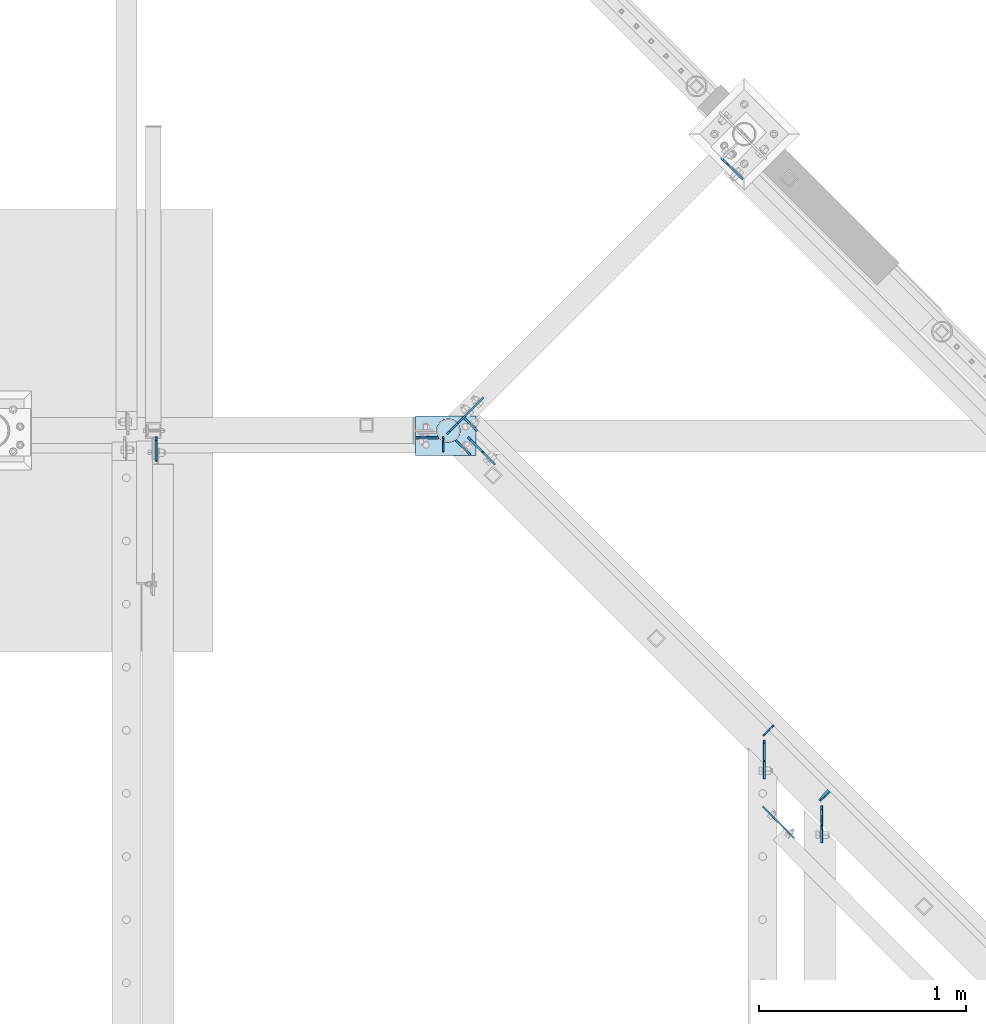
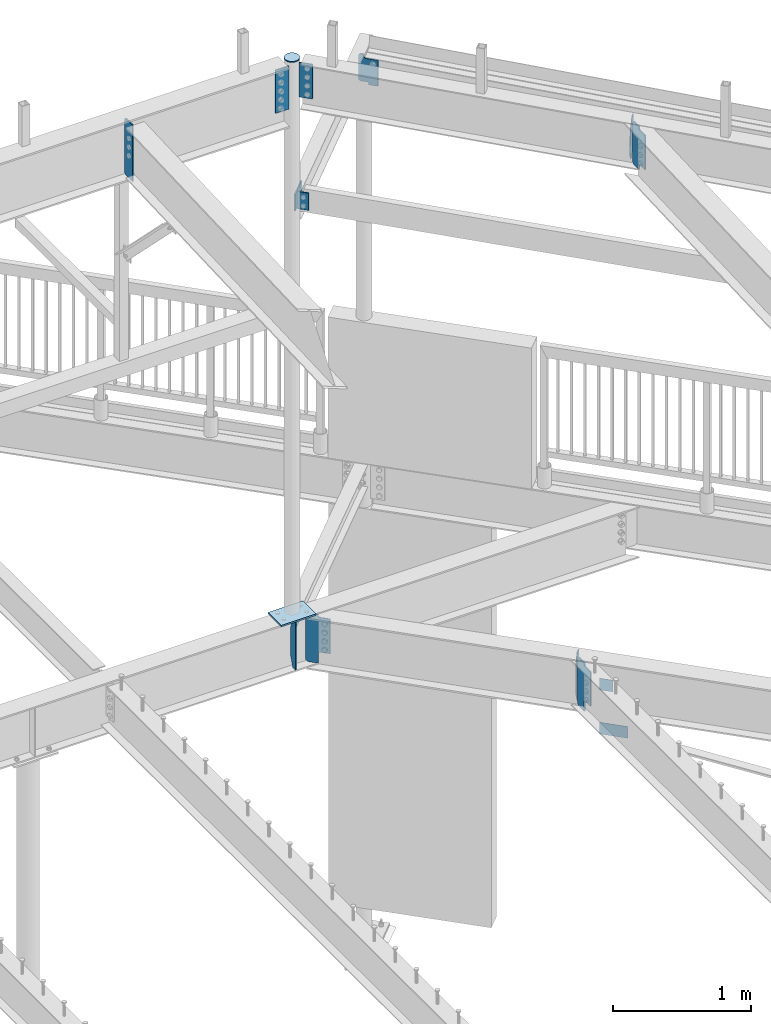
# One storey, part 868 of 975: 17 plates.
"""IFC2X3 building model written with IfcOpenShell, lengths in millimetres."""

from ifc_helpers import new_model, si_unit, frame, origin_with_axes, place, context, subcontext, project, spatial, faceted_brep, material, type_object, element, save


model = new_model("IFC2X3")

# Units and contexts
model_context = context("Model", 3, precision=1e-05, world=origin_with_axes())
body_context = subcontext(model_context, "Body", "Model", "MODEL_VIEW")
ifc_project = project(units=[si_unit("LENGTHUNIT", "METRE", prefix="MILLI"), si_unit("AREAUNIT", "SQUARE_METRE"), si_unit("VOLUMEUNIT", "CUBIC_METRE"), si_unit("MASSUNIT", "GRAM", prefix="KILO"), si_unit("TIMEUNIT", "SECOND"), si_unit("PLANEANGLEUNIT", "RADIAN"), si_unit("SOLIDANGLEUNIT", "STERADIAN"), si_unit("THERMODYNAMICTEMPERATUREUNIT", "DEGREE_CELSIUS"), si_unit("LUMINOUSINTENSITYUNIT", "LUMEN")], contexts=[model_context])

# Site, building, storey
site_placement = place(None, origin_with_axes())
site = spatial("IfcSite", under=ifc_project, at=site_placement, CompositionType="ELEMENT")
building_placement = place(site_placement, origin_with_axes())
building = spatial("IfcBuilding", under=site, at=building_placement, Name="Undefined", CompositionType="ELEMENT")
storey_placement = place(building_placement, origin_with_axes())
storey = spatial("IfcBuildingStorey", under=building, at=storey_placement, Name="Undefined", CompositionType="ELEMENT", Elevation=0.0)

# Plates
ifc_material = material(Name="STEEL/A36")
plate_type_1 = type_object("IfcPlateType", PredefinedType="NOTDEFINED")
plate_1_placement = place(storey_placement, frame((26652.5379999199, 19152.1483646332, 3513.13749999999), z_axis=(0.0, -0.707106781186557, 0.707106781186538), x_axis=(0.0, -0.707106781186538, -0.707106781186557)))
element("IfcPlate", 1, at=plate_1_placement, inside=storey, type_object=plate_type_1, material=ifc_material, Name="PLATE", context=body_context, shape_type="Brep", body=[
    faceted_brep([(0.0, -4.76250000000073, 0.0), (-278.387939453176, -4.76250000000073, 278.387939453169), (-278.387939453176, 4.76250000000073, 278.387939453169), (0.0, 4.76250000000073, 0.0), (-278.38793945321, -4.76250000000073, 303.083648681655), (-278.38793945321, 4.76250000000073, 303.083648681655), (-221.677108764869, -4.76250000000073, 359.79446411121), (-221.677108764869, 4.76250000000073, 359.79446411121), (-212.696855580698, -4.76250000000073, 350.814210927037), (-212.696855580698, 4.76250000000073, 350.814210927037), (-208.576678758616, -4.76250000000073, 348.061196879957), (-208.576678758616, 4.76250000000073, 348.061196879957), (-203.716598828325, -4.76250000000073, 347.094467103965), (-203.716598828325, 4.76250000000073, 347.094467103965), (-198.856519014682, -4.76250000000073, 348.06119746635), (-198.856519014682, 4.76250000000073, 348.06119746635), (-194.736342524782, -4.76250000000073, 350.814212010551), (-194.736342524782, 4.76250000000073, 350.814212010551), (-140.484863281623, -4.76250000000073, 405.06570434543), (-140.484863281623, 4.76250000000073, 405.06570434543), (75.0412826534775, -4.76250000000073, 189.539550780943), (75.0412826534775, 4.76250000000073, 189.539550780943), (20.7898064371366, -4.76250000000073, 135.28807129167), (20.7898064371366, 4.76250000000073, 135.28807129167), (18.0367927308962, -4.76250000000073, 131.167894909355), (18.0367927308962, 4.76250000000073, 131.167894909355), (17.0700628849681, -4.76250000000073, 126.307815558852), (17.0700628849681, 4.76250000000073, 126.307815558852), (18.0367927443185, -4.76250000000073, 121.447736211016), (18.0367927443185, 4.76250000000073, 121.447736211016), (20.789806461933, -4.76250000000073, 117.327559836287), (20.789806461933, 4.76250000000073, 117.327559836287), (81.4065322874321, -4.76250000000073, 56.710830688311), (81.4065322874321, 4.76250000000073, 56.710830688311), (24.6957035064406, -4.76250000000073, -6.3664629124105e-11), (24.6957035064406, 4.76250000000073, -6.3664629124105e-11)], [[[0, 1, 2, 3]], [[1, 4, 5, 2]], [[4, 6, 7, 5]], [[6, 8, 9, 7]], [[8, 10, 11, 9]], [[10, 12, 13, 11]], [[12, 14, 15, 13]], [[14, 16, 17, 15]], [[16, 18, 19, 17]], [[18, 20, 21, 19]], [[20, 22, 23, 21]], [[22, 24, 25, 23]], [[24, 26, 27, 25]], [[26, 28, 29, 27]], [[28, 30, 31, 29]], [[30, 32, 33, 31]], [[32, 34, 35, 33]], [[34, 0, 3, 35]], [[5, 7, 9, 11, 13, 15, 17, 19, 21, 23, 25, 27, 29, 31, 33, 35, 3, 2]], [[34, 32, 30, 28, 26, 24, 22, 20, 18, 16, 14, 12, 10, 8, 6, 4, 1, 0]]]),
])
plate_2_placement = place(storey_placement, frame((25119.1665069379, 20629.0676564386, 3513.13750000001), z_axis=(0.499437385414003, 0.500561982414933, 0.707106781053369), x_axis=(0.499437385225907, 0.500561982226343, -0.707106781319726)))
element("IfcPlate", 2, at=plate_2_placement, inside=storey, type_object=plate_type_1, material=ifc_material, Name="PLATE", context=body_context, shape_type="Brep", body=[
    faceted_brep([(0.0, -4.76250000000073, 0.0), (-278.387939453176, -4.76250000000073, 278.387939453169), (-278.387939453176, 4.76250000000073, 278.387939453169), (0.0, 4.76250000000073, 0.0), (-278.38793945321, -4.76250000000073, 303.083648681655), (-278.38793945321, 4.76250000000073, 303.083648681655), (-221.945663452043, -4.76249999999891, 359.525909424025), (-221.945663452047, 4.76250000000255, 359.525909424017), (-212.965409184344, -4.76249999999482, 350.545655156311), (-212.965409184348, 4.762500000003, 350.545655156307), (-208.84523271619, -4.762499999993, 347.792641255823), (-208.845232716198, 4.76250000000846, 347.792641255823), (-203.985153198151, -4.7624999999889, 346.825911333235), (-203.985153198159, 4.76250000001255, 346.825911333228), (-199.125073680105, -4.76249999998345, 347.792641255815), (-199.125073680116, 4.76250000001437, 347.792641255808), (-195.004897211962, -4.76249999997435, 350.545655156289), (-195.004897211966, 4.76250000001983, 350.545655156282), (-140.777908325181, -4.76249999989614, 404.772644043063), (-140.777908325188, 4.76250000010168, 404.772644043056), (-33.014831543027, -4.76249999985794, 297.009582519517), (-33.0148315430342, 4.76250000013988, 297.009582519509), (-87.241820719526, -4.76249999994343, 242.782593343021), (-87.2418207195296, 4.76250000005984, 242.782593343014), (-89.9948345808043, -4.76249999994707, 238.662416969506), (-89.9948345808116, 4.76250000005257, 238.662416969499), (-90.9615645425874, -4.76249999995071, 233.80233756169), (-90.9615645425947, 4.76250000004893, 233.802337561687), (-89.9948347375976, -4.76249999995434, 228.94225812269), (-89.9948347376048, 4.76250000004711, 228.942258122683), (-87.2418210092474, -4.76249999995071, 224.822081660353), (-87.2418210092546, 4.76250000004711, 224.822081660343), (81.1379776000067, -4.76249999989795, 56.4422721861774), (81.1379775999994, 4.7625000001035, 56.4422721861702), (24.6957035064406, -4.76250000000073, -6.3664629124105e-11), (24.6957035064406, 4.76250000000073, -6.3664629124105e-11)], [[[0, 1, 2, 3]], [[1, 4, 5, 2]], [[4, 6, 7, 5]], [[6, 8, 9, 7]], [[8, 10, 11, 9]], [[10, 12, 13, 11]], [[12, 14, 15, 13]], [[14, 16, 17, 15]], [[16, 18, 19, 17]], [[18, 20, 21, 19]], [[20, 22, 23, 21]], [[22, 24, 25, 23]], [[24, 26, 27, 25]], [[26, 28, 29, 27]], [[28, 30, 31, 29]], [[30, 32, 33, 31]], [[32, 34, 35, 33]], [[34, 0, 3, 35]], [[5, 7, 9, 11, 13, 15, 17, 19, 21, 23, 25, 27, 29, 31, 33, 35, 3, 2]], [[34, 32, 30, 28, 26, 24, 22, 20, 18, 16, 14, 12, 10, 8, 6, 4, 1, 0]]]),
])
plate_type_2 = type_object("IfcPlateType", PredefinedType="NOTDEFINED")
plate_3_placement = place(storey_placement, frame((25161.2852750803, 20601.492171903, 8810.17242494559), z_axis=(0.706980057333141, -0.70723348233326, 0.0), x_axis=(0.0, 0.0, -1.0)))
element("IfcPlate", 3, at=plate_3_placement, inside=storey, type_object=plate_type_2, material=ifc_material, Name="PLATE", context=body_context, shape_type="Brep", body=[
    faceted_brep([(0.0, -4.76250000000073, 0.0), (3.09228198602796e-11, -4.76250000006621, 101.59999847407), (3.09228198602796e-11, 4.7624999999407, 101.599998474074), (0.0, 4.76250000000073, 0.0), (304.799987792969, -4.76250000006621, 101.59999847407), (304.799987792969, 4.7624999999407, 101.599998474074), (304.799987792969, -4.76249999999982, 0.0), (304.799987792969, 4.76249999999982, 0.0)], [[[0, 1, 2, 3]], [[1, 4, 5, 2]], [[4, 6, 7, 5]], [[6, 0, 3, 7]], [[5, 7, 3, 2]], [[6, 4, 1, 0]]]),
])
plate_type_3 = type_object("IfcPlateType", PredefinedType="NOTDEFINED")
plate_4_placement = place(storey_placement, frame((26796.3474877378, 18678.8978916903, 3536.95), z_axis=(-0.70465068336211, 0.709554377364632, 0.0), x_axis=(0.0, 0.0, -1.0)))
element("IfcPlate", 4, at=plate_4_placement, inside=storey, type_object=plate_type_3, material=ifc_material, Name="PLATE", context=body_context, shape_type="Brep", body=[
    faceted_brep([(0.0, -2.38100000000122, -1.81898940354586e-12), (0.0, -2.38100000016129, 212.955001830956), (0.0, 2.38099999984115, 212.95500183096), (0.0, 2.38099999999758, 3.63797880709171e-12), (101.599998474121, -2.38100000016129, 212.955001830956), (101.599998474121, 2.38099999984115, 212.95500183096), (101.599998474121, -2.38100000000122, -1.81898940354586e-12), (101.599998474121, 2.38099999999758, 3.63797880709171e-12)], [[[0, 1, 2, 3]], [[1, 4, 5, 2]], [[4, 6, 7, 5]], [[6, 0, 3, 7]], [[5, 7, 3, 2]], [[6, 4, 1, 0]]]),
])
plate_5_placement = place(storey_placement, frame((26717.9173874866, 18757.9463602332, 3925.8875), z_axis=(-0.705007718837806, 0.709199630836842, 0.0), x_axis=(0.0, 0.0, -1.0)))
element("IfcPlate", 5, at=plate_5_placement, inside=storey, type_object=plate_type_3, material=ifc_material, Name="PLATE", context=body_context, shape_type="Brep", body=[
    faceted_brep([(0.0, -2.38100000000122, -1.81898940354586e-12), (0.0, -2.38099999989936, 101.599998474278), (0.0, 2.38100000010309, 101.599998474281), (0.0, 2.38099999999758, 3.63797880709171e-12), (101.599998474121, -2.38099999989936, 101.599998474278), (101.599998474121, 2.38100000010309, 101.599998474281), (101.599998474121, -2.38100000000122, -1.81898940354586e-12), (101.599998474121, 2.38099999999758, 3.63797880709171e-12)], [[[0, 1, 2, 3]], [[1, 4, 5, 2]], [[4, 6, 7, 5]], [[6, 0, 3, 7]], [[5, 7, 3, 2]], [[6, 4, 1, 0]]]),
])
plate_type_4 = type_object("IfcPlateType", PredefinedType="NOTDEFINED")
plate_6_placement = place(storey_placement, frame((26929.5562499969, 18834.5598628626, 8389.0940191122), z_axis=(0.0, -0.707106781186557, 0.707106781186538), x_axis=(0.0, -0.707106781186538, -0.707106781186557)))
element("IfcPlate", 6, at=plate_6_placement, inside=storey, type_object=plate_type_4, material=ifc_material, Name="PLATE", context=body_context, shape_type="Brep", body=[
    faceted_brep([(0.0, -4.76250000000073, 0.0), (-244.547378540154, -4.76250000000073, 244.547378540008), (-244.547378540154, 4.76250000000073, 244.547378540008), (0.0, 4.76250000000073, 0.0), (-244.547378540159, -4.76250000000073, 269.24307250974), (-244.547378540159, 4.76250000000073, 269.24307250974), (-192.102493286275, -4.76250000000073, 319.50839233397), (-192.102493286275, 4.76250000000073, 319.50839233397), (-183.944729921943, -4.76250000000073, 310.996900614104), (-183.944729921943, 4.76250000000073, 310.996900614104), (-179.829062771194, -4.76250000000073, 308.133163747397), (-179.829062771194, 4.76250000000073, 308.133163747397), (-174.925788331428, -4.76250000000073, 307.085497433226), (-174.925788331428, 4.76250000000073, 307.085497433226), (-169.999162764503, -4.76250000000073, 308.017197739561), (-169.999162764503, 4.76250000000073, 308.017197739561), (-165.817081890433, -4.76250000000073, 310.78304381269), (-165.817081890433, 4.76250000000073, 310.78304381269), (-111.638481140279, -4.76250000000073, 364.704772949239), (-111.638481140279, 4.76250000000073, 364.704772949239), (103.887664794889, -4.76250000000073, 149.178634643614), (103.887664794889, 4.76250000000073, 149.178634643614), (50.5272904054582, -4.76250000000073, 96.0344850912634), (50.5272904054582, 4.76250000000073, 96.0344850912634), (47.7894791640465, -4.76250000000073, 91.9760843124814), (47.7894791640465, 4.76250000000073, 91.9760843124814), (46.7901544007073, -4.76250000000073, 87.1836342822598), (46.7901544007073, 4.76250000000073, 87.1836342822598), (47.6778066921579, -4.76250000000073, 82.3692495153045), (47.6778066921579, 4.76250000000073, 82.3692495153045), (50.3205389759787, -4.76250000000073, 78.2483038288347), (50.3205389759787, 4.76250000000073, 78.2483038288347), (77.1405868530273, -4.76250000000073, 50.2653083801615), (77.1405868530273, 4.76250000000073, 50.2653083801615), (24.6957035064406, -4.76250000000073, -6.3664629124105e-11), (24.6957035064406, 4.76250000000073, -6.3664629124105e-11)], [[[0, 1, 2, 3]], [[1, 4, 5, 2]], [[4, 6, 7, 5]], [[6, 8, 9, 7]], [[8, 10, 11, 9]], [[10, 12, 13, 11]], [[12, 14, 15, 13]], [[14, 16, 17, 15]], [[16, 18, 19, 17]], [[18, 20, 21, 19]], [[20, 22, 23, 21]], [[22, 24, 25, 23]], [[24, 26, 27, 25]], [[26, 28, 29, 27]], [[28, 30, 31, 29]], [[30, 32, 33, 31]], [[32, 34, 35, 33]], [[34, 0, 3, 35]], [[5, 7, 9, 11, 13, 15, 17, 19, 21, 23, 25, 27, 29, 31, 33, 35, 3, 2]], [[34, 32, 30, 28, 26, 24, 22, 20, 18, 16, 14, 12, 10, 8, 6, 4, 1, 0]]]),
])
plate_type_5 = type_object("IfcPlateType", PredefinedType="NOTDEFINED")
plate_7_placement = place(storey_placement, frame((25171.9197615242, 20681.939696592, 7594.6), z_axis=(0.706311124041062, 0.707901544041155, 0.0), x_axis=(0.0, 0.0, -1.0)))
element("IfcPlate", 7, at=plate_7_placement, inside=storey, type_object=plate_type_5, material=ifc_material, Name="PLATE", context=body_context, shape_type="Brep", body=[
    faceted_brep([(0.0, -4.76250000000073, 0.0), (0.0, -4.76250000036362, 177.802673339778), (0.0, 4.76249999963784, 177.802673339796), (0.0, 4.76250000000073, 0.0), (152.399993896484, -4.76250000036362, 177.802673339778), (152.399993896484, 4.76249999963784, 177.802673339796), (152.399993896484, -4.76250000000073, 0.0), (152.399993896484, 4.76250000000073, 0.0)], [[[0, 1, 2, 3]], [[1, 4, 5, 2]], [[4, 6, 7, 5]], [[6, 0, 3, 7]], [[5, 7, 3, 2]], [[6, 4, 1, 0]]]),
])
plate_type_6 = type_object("IfcPlateType", PredefinedType="NOTDEFINED")
plate_8_placement = place(storey_placement, frame((26922.6965522737, 18855.1680896913, 8753.55425938264), z_axis=(-0.0212034286822236, 0.0212110253315295, -0.999550152326787), x_axis=(0.707233416345083, 0.706980123344965, 0.0)))
element("IfcPlate", 8, at=plate_8_placement, inside=storey, type_object=plate_type_6, material=ifc_material, Name="PLATE", context=body_context, shape_type="Brep", body=[
    faceted_brep([(2.81943357549608e-10, -3.17500000006476, 92.0749969482258), (0.0, -3.17499999999927, 288.924987792969), (0.0, 3.17499999999927, 288.924987792969), (2.67391442321241e-10, 3.17499999993743, 92.0749969482295), (31.7500000011059, -3.17500000022483, 380.999999999935), (31.7500000010932, 3.17499999978099, 380.999999999938), (66.6750030521289, -3.17500000019572, 380.999999999934), (66.6750030521143, 3.17499999981374, 380.999999999937), (66.6750030516614, -3.17499999994834, 7.09405867382884e-11), (66.6750030516505, 3.17500000005384, 7.36690708436072e-11), (31.75000000004, -3.17500000000246, 0.0), (31.7500000000473, 3.17499999999791, 0.0)], [[[0, 1, 2, 3]], [[1, 4, 5, 2]], [[4, 6, 7, 5]], [[6, 8, 9, 7]], [[8, 10, 11, 9]], [[10, 0, 3, 11]], [[5, 7, 9, 11, 3, 2]], [[10, 8, 6, 4, 1, 0]]]),
])
plate_type_7 = type_object("IfcPlateType", PredefinedType="NOTDEFINED")
plate_9_placement = place(storey_placement, frame((23714.8682500839, 20616.86255, 8323.2625), z_axis=(0.0, 0.0, 1.0), x_axis=(0.0, -1.0, 0.0)))
element("IfcPlate", 9, at=plate_9_placement, inside=storey, type_object=plate_type_7, material=ifc_material, Name="PLATE", context=body_context, shape_type="Brep", body=[
    faceted_brep([(0.0, -4.76250000000073, 17.4624996185303), (0.0, -4.76250000000073, 484.187494277954), (0.0, 4.76250000000073, 484.187494277954), (0.0, 4.76250000000073, 17.4624996185303), (17.4624996185303, -4.76250000000073, 501.649993896484), (17.4624996185303, 4.76250000000073, 501.649993896484), (117.111587524414, -4.76250000000073, 501.649993896484), (117.111587524414, 4.76250000000073, 501.649993896484), (117.111587524414, -4.76250000000073, 0.0), (117.111587524414, 4.76250000000073, 0.0), (17.4624996185303, -4.76250000000073, 0.0), (17.4624996185303, 4.76250000000073, 0.0)], [[[0, 1, 2, 3]], [[1, 4, 5, 2]], [[4, 6, 7, 5]], [[6, 8, 9, 7]], [[8, 10, 11, 9]], [[10, 0, 3, 11]], [[5, 7, 9, 11, 3, 2]], [[10, 8, 6, 4, 1, 0]]]),
])
plate_type_8 = type_object("IfcPlateType", PredefinedType="NOTDEFINED")
plate_10_placement = place(storey_placement, frame((25221.5899649125, 20614.4087502386, 3513.1375), z_axis=(0.498515780086065, -0.501479827086575, 0.707106781208044), x_axis=(0.498515780116378, -0.501479827117064, -0.707106781165051)))
element("IfcPlate", 10, at=plate_10_placement, inside=storey, type_object=plate_type_8, material=ifc_material, Name="PLATE", context=body_context, shape_type="Brep", body=[
    faceted_brep([(0.0, -4.76250000000073, 0.0), (-278.387939453176, -4.76250000000073, 278.387939453169), (-278.387939453176, 4.76250000000073, 278.387939453169), (0.0, 4.76250000000073, 0.0), (-278.38793945321, -4.76250000000073, 303.083648681655), (-278.38793945321, 4.76250000000073, 303.083648681655), (-222.065383911351, -4.76250000000073, 359.406188964731), (-222.065383911351, 4.76250000000073, 359.406188964731), (-213.085130727788, -4.76250000000073, 350.425935781164), (-213.085130727788, 4.76250000000073, 350.425935781164), (-208.96495390551, -4.76250000000073, 347.672921734), (-208.96495390551, 4.76250000000073, 347.672921734), (-204.104873974989, -4.76250000000073, 346.706191958092), (-204.104873974989, 4.76250000000073, 346.706191958092), (-199.244794161175, -4.76250000000073, 347.672922320722), (-199.244794161175, 4.76250000000073, 347.672922320722), (-195.124617671267, -4.76250000000073, 350.425936865282), (-195.124617671267, 4.76250000000073, 350.425936865282), (-140.908508301152, -4.76250000000073, 404.642059325903), (-140.908508301152, 4.76250000000073, 404.642059325903), (74.6176452633408, -4.76250000000073, 189.115905761417), (74.6176452633408, 4.76250000000073, 189.115905761417), (20.4015346260785, -4.76250000000073, 134.899796760466), (20.4015346260785, 4.76250000000073, 134.899796760466), (17.648520595154, -4.76250000000073, 130.779620169014), (17.648520595154, 4.76250000000073, 130.779620169014), (16.6817906675096, -4.76250000000073, 125.919540473547), (16.6817906675096, 4.76250000000073, 125.919540473547), (17.6485207216101, -4.76250000000073, 121.05946080323), (17.6485207216101, 4.76250000000073, 121.05946080323), (20.4015348597459, -4.76250000000073, 116.939284283402), (20.4015348597459, 4.76250000000073, 116.939284283402), (81.0182647703441, -4.76250000000073, 56.3225593565294), (81.0182647703441, 4.76250000000073, 56.3225593565294), (24.6957035064406, -4.76250000000073, -6.3664629124105e-11), (24.6957035064406, 4.76250000000073, -6.3664629124105e-11)], [[[0, 1, 2, 3]], [[1, 4, 5, 2]], [[4, 6, 7, 5]], [[6, 8, 9, 7]], [[8, 10, 11, 9]], [[10, 12, 13, 11]], [[12, 14, 15, 13]], [[14, 16, 17, 15]], [[16, 18, 19, 17]], [[18, 20, 21, 19]], [[20, 22, 23, 21]], [[22, 24, 25, 23]], [[24, 26, 27, 25]], [[26, 28, 29, 27]], [[28, 30, 31, 29]], [[30, 32, 33, 31]], [[32, 34, 35, 33]], [[34, 0, 3, 35]], [[5, 7, 9, 11, 13, 15, 17, 19, 21, 23, 25, 27, 29, 31, 33, 35, 3, 2]], [[34, 32, 30, 28, 26, 24, 22, 20, 18, 16, 14, 12, 10, 8, 6, 4, 1, 0]]]),
])
plate_type_9 = type_object("IfcPlateType", PredefinedType="NOTDEFINED")
plate_11_placement = place(storey_placement, frame((25101.7589783175, 20545.5350997173, 3495.675), z_axis=(0.0, 0.0, 1.0), x_axis=(0.0, 1.0, 0.0)))
element("IfcPlate", 11, at=plate_11_placement, inside=storey, type_object=plate_type_9, material=ifc_material, Name="PLATE", context=body_context, shape_type="Brep", body=[
    faceted_brep([(0.0, -3.17499999999927, 0.0), (0.0, -3.17499999999927, 428.625), (0.0, 3.17499999999927, 428.625), (0.0, 3.17499999999927, 0.0), (40.4812469482422, -3.17499999999927, 428.625), (40.4812469482422, 3.17499999999927, 428.625), (72.2312469482422, -3.17499999999927, 336.550003051758), (72.2312469482422, 3.17499999999927, 336.550003051758), (72.2312469482422, -3.17499999999927, 92.0749969482422), (72.2312469482422, 3.17499999999927, 92.0749969482422), (40.4812469482422, -3.17499999999927, 0.0), (40.4812469482422, 3.17499999999927, 0.0)], [[[0, 1, 2, 3]], [[1, 4, 5, 2]], [[4, 6, 7, 5]], [[6, 8, 9, 7]], [[8, 10, 11, 9]], [[10, 0, 3, 11]], [[5, 7, 9, 11, 3, 2]], [[10, 8, 6, 4, 1, 0]]]),
])
plate_12_placement = place(storey_placement, frame((26698.6410074632, 19224.2748386985, 3495.675), z_axis=(0.0, 0.0, 1.0), x_axis=(-0.709199630836852, -0.705007718837796, 0.0)))
element("IfcPlate", 12, at=plate_12_placement, inside=storey, type_object=plate_type_9, material=ifc_material, Name="PLATE", context=body_context, shape_type="Brep", body=[
    faceted_brep([(0.0, -3.17499999999927, 0.0), (0.0, -3.17499999999927, 428.625), (0.0, 3.17499999999927, 428.625), (0.0, 3.17499999999927, 0.0), (38.8937454223196, -3.17499999997199, 428.625), (38.893745422316, 3.17500000004111, 428.625), (72.2312469481658, -3.1749999999447, 344.487503051758), (72.2312469481622, 3.17500000006476, 344.487503051758), (72.2312469481658, -3.1749999999447, 84.1374969482422), (72.2312469481622, 3.17500000006476, 84.1374969482422), (38.8937454223196, -3.17499999997199, 0.0), (38.893745422316, 3.17500000004111, 0.0)], [[[0, 1, 2, 3]], [[1, 4, 5, 2]], [[4, 6, 7, 5]], [[6, 8, 9, 7]], [[8, 10, 11, 9]], [[10, 0, 3, 11]], [[5, 7, 9, 11, 3, 2]], [[10, 8, 6, 4, 1, 0]]]),
])
plate_type_10 = type_object("IfcPlateType", PredefinedType="NOTDEFINED")
plate_13_placement = place(storey_placement, frame((25203.8112794912, 20707.1514550932, 7593.46280577227), z_axis=(0.706980057333141, -0.70723348233326, 0.0), x_axis=(0.0, 0.0, -1.0)))
element("IfcPlate", 13, at=plate_13_placement, inside=storey, type_object=plate_type_10, material=ifc_material, Name="PLATE", context=body_context, shape_type="Brep", body=[
    faceted_brep([(0.0, -4.76250000000073, 0.0), (0.0, -4.76249999999982, 88.9000015258789), (0.0, 4.76249999999982, 88.9000015258789), (0.0, 4.76250000000073, 0.0), (152.399993896484, -4.76249999999982, 88.9000015258789), (152.399993896484, 4.76249999999982, 88.9000015258789), (152.399993896484, -4.76250000000073, 0.0), (152.399993896484, 4.76250000000073, 0.0)], [[[0, 1, 2, 3]], [[1, 4, 5, 2]], [[4, 6, 7, 5]], [[6, 0, 3, 7]], [[5, 7, 3, 2]], [[6, 4, 1, 0]]]),
])
plate_type_11 = type_object("IfcPlateType", PredefinedType="NOTDEFINED")
plate_14_placement = place(storey_placement, frame((26471.7989292186, 21937.0951557959, 7373.93750000211), z_axis=(0.0, 0.0, 1.0), x_axis=(-0.707895110754486, 0.70631757175501, 0.0)))
element("IfcPlate", 14, at=plate_14_placement, inside=storey, type_object=plate_type_11, material=ifc_material, Name="PLATE", context=body_context, shape_type="Brep", body=[
    faceted_brep([(-35.4927914652562, -4.76249999997526, -23.4120941162109), (-35.4928782213083, 4.76250000002619, -23.4120941162109), (-35.4928779076163, 4.76250000002619, -6.35000060148923), (-35.4927911515679, -4.76249999997526, -6.35000060168841), (-35.0095128561788, 4.76250000002619, -3.91996074162034), (-35.0094261001304, -4.76249999997526, -3.91996074181952), (-33.6330057454925, 4.76250000002619, -1.85987247461071), (-33.6329189894441, -4.76249999997526, -1.85987247480989), (-31.5729173248001, 4.76250000002619, -0.483365593860071), (-31.5728305687517, -4.76249999997526, -0.483365594059251), (-29.1428774108881, 4.76250000002619, -8.13601218396798e-07), (-29.1427906548379, -4.76249999998254, -8.13801307231188e-07), (-10.0000008116149, -4.76250000019354, -2.59797889157198e-06), (-9.9999790191614, 4.76250000001164, 6.3664629124105e-12), (-108.899978637741, -4.76249999991705, -23.4120941162109), (-108.899978637741, -4.76249999991705, 205.187911987305), (-108.899978637734, 4.7625000000844, 205.187911987305), (-108.899978637734, 4.7625000000844, -23.4120941162109), (-19.9999999967185, -4.76249999998254, 205.187911987305), (-19.9999999967094, 4.76250000001164, 205.187911987305), (-12.3463313494813, -4.76249999999709, 206.710321337051), (-12.346331349474, 4.76250000001164, 206.710321337051), (-5.85786437308707, -4.76249999999709, 211.04577636347), (-5.85786437307615, 4.76250000001164, 211.04577636347), (-1.52240934656948, -4.76249999999709, 217.5342433398), (-1.52240934656584, 4.76250000000437, 217.5342433398), (3.28691385220736e-09, -4.76249999999709, 225.187911987013), (3.29782778862864e-09, 4.76249999999709, 225.187911987013), (3.52520146407187e-09, -4.76250000000437, 241.300003051758), (3.52883944287896e-09, 4.76250000000437, 241.300003051758), (24.131162643429, -4.76250000001892, 241.300003051758), (24.1311626434381, 4.76249999998254, 241.300003051758), (38.418663024906, -4.76250000003347, 227.012502670288), (38.4186630249133, 4.76249999997526, 227.012502670288), (38.418663024906, -4.76250000003347, 14.2875003814424), (38.4186630249133, 4.76249999997526, 14.2875003814424), (24.131162643429, -4.76250000001892, -1.72803993336856e-11), (24.1311626434381, 4.76249999998254, -1.72803993336856e-11), (0.0, -4.76250000000073, 0.0), (0.0, 4.76250000000073, 0.0)], [[[0, 1, 2, 3]], [[3, 2, 4, 5]], [[5, 4, 6, 7]], [[7, 6, 8, 9]], [[9, 8, 10, 11]], [[12, 11, 10, 13]], [[14, 15, 16, 17]], [[15, 18, 19, 16]], [[18, 20, 21, 19]], [[20, 22, 23, 21]], [[22, 24, 25, 23]], [[24, 26, 27, 25]], [[26, 28, 29, 27]], [[28, 30, 31, 29]], [[30, 32, 33, 31]], [[32, 34, 35, 33]], [[34, 36, 37, 35]], [[36, 38, 39, 37]], [[39, 38, 12, 13]], [[8, 6, 4, 2, 1, 17, 16, 19, 21, 23, 25, 27, 29, 31, 33, 35, 37, 39, 13, 10]], [[14, 17, 1, 0]], [[38, 36, 34, 32, 30, 28, 26, 24, 22, 20, 18, 15, 14, 0, 3, 5, 7, 9, 11, 12]]]),
])
plate_type_12 = type_object("IfcPlateType", PredefinedType="NOTDEFINED")
plate_15_placement = place(storey_placement, frame((25069.8420609686, 20704.175, 8834.4375), z_axis=(0.0, -1.0, 0.0), x_axis=(1.0, 0.0, 0.0)))
element("IfcPlate", 15, at=plate_15_placement, inside=storey, type_object=plate_type_12, material=ifc_material, Name="PLATE", context=body_context, shape_type="Brep", body=[
    faceted_brep([(-1.45519152283669e-10, -4.76250000000073, 57.1500015256606), (4.35028483294354, -4.76250000000073, 79.0203602693728), (4.35028483294354, 4.76250000000073, 79.0203602693728), (-1.45519152283669e-10, 4.76250000000073, 57.1500015256606), (16.7388479019119, -4.76250000000073, 97.5611551495967), (16.7388479019119, 4.76250000000073, 97.5611551495967), (35.2796427821067, -4.76250000000073, 109.949718218613), (35.2796427821067, 4.76250000000073, 109.949718218613), (57.1500015258789, -4.76250000000073, 114.300003051758), (57.1500015258789, 4.76250000000073, 114.300003051758), (79.0203602694728, -4.76250000000073, 109.949718218628), (79.0203602694728, 4.76250000000073, 109.949718218628), (97.5611551496495, -4.76250000000073, 97.5611551496477), (97.5611551496495, 4.76250000000073, 97.5611551496477), (109.949718218627, -4.76250000000073, 79.020360269471), (109.949718218627, 4.76250000000073, 79.020360269471), (114.300003051758, -4.76250000000073, 57.1500015258061), (114.300003051758, 4.76250000000073, 57.1500015258061), (109.949718218621, -4.76250000000073, 35.2796427821959), (109.949718218621, 4.76250000000073, 35.2796427821959), (97.5611551496231, -4.76250000000073, 16.7388479020083), (97.5611551496231, 4.76250000000073, 16.7388479020083), (79.020360269421, -4.76250000000073, 4.3502848330354), (79.020360269421, 4.76250000000073, 4.3502848330354), (57.1500015256597, -4.76250000000073, -7.27595761418343e-11), (57.1500015256597, 4.76250000000073, -7.27595761418343e-11), (35.2796427821222, -4.76250000000073, 4.35028483306451), (35.2796427821222, 4.76250000000073, 4.35028483306451), (16.7388479019883, -4.76250000000073, 16.7388479020083), (16.7388479019883, 4.76250000000073, 16.7388479020083), (4.35028483301994, -4.76250000000073, 35.2796427821268), (4.35028483301994, 4.76250000000073, 35.2796427821268)], [[[0, 1, 2, 3]], [[1, 4, 5, 2]], [[4, 6, 7, 5]], [[6, 8, 9, 7]], [[8, 10, 11, 9]], [[10, 12, 13, 11]], [[12, 14, 15, 13]], [[14, 16, 17, 15]], [[16, 18, 19, 17]], [[18, 20, 21, 19]], [[20, 22, 23, 21]], [[22, 24, 25, 23]], [[24, 26, 27, 25]], [[26, 28, 29, 27]], [[28, 30, 31, 29]], [[30, 0, 3, 31]], [[5, 7, 9, 11, 13, 15, 17, 19, 21, 23, 25, 27, 29, 31, 3, 2]], [[30, 28, 26, 24, 22, 20, 18, 16, 14, 12, 10, 8, 6, 4, 1, 0]]]),
])
plate_type_13 = type_object("IfcPlateType", PredefinedType="NOTDEFINED")
plate_16_placement = place(storey_placement, frame((25079.0093338443, 20612.10005, 8801.1), z_axis=(-0.999999999999998, 6.90000001668524e-08, 0.0), x_axis=(0.0, 0.0, -1.0)))
element("IfcPlate", 16, at=plate_16_placement, inside=storey, type_object=plate_type_13, material=ifc_material, Name="PLATE", context=body_context, shape_type="Brep", body=[
    faceted_brep([(0.0, -4.76250000000073, 0.0), (0.0, -4.76250000000073, 110.376586914062), (0.0, 4.76250000000073, 110.376586914062), (0.0, 4.76250000000073, 0.0), (381.0, -4.76250000000073, 110.376586914062), (381.0, 4.76250000000073, 110.376586914062), (381.0, -4.76250000000073, 0.0), (381.0, 4.76250000000073, 0.0)], [[[0, 1, 2, 3]], [[1, 4, 5, 2]], [[4, 6, 7, 5]], [[6, 0, 3, 7]], [[5, 7, 3, 2]], [[6, 4, 1, 0]]]),
])
plate_type_14 = type_object("IfcPlateType", PredefinedType="NOTDEFINED")
plate_17_placement = place(storey_placement, frame((24968.2420609686, 20716.875, 3943.35), z_axis=(1.0, 0.0, 0.0), x_axis=(0.0, -1.0, 0.0)))
element("IfcPlate", 17, at=plate_17_placement, inside=storey, type_object=plate_type_14, material=ifc_material, Name="PLATE", context=body_context, shape_type="Brep", body=[
    faceted_brep([(0.0, -6.34999999998763, -3.63797880709171e-12), (0.0, -6.34999999999991, 292.100006103516), (0.0, 6.34999999999991, 292.100006103516), (0.0, 6.34999999999491, 5.45696821063757e-12), (190.499496459961, -6.34999999999991, 292.100006103516), (190.499496459961, 6.34999999999991, 292.100006103516), (190.499496459961, -6.34999999999991, 0.0), (190.499496459961, 6.34999999999991, 0.0)], [[[0, 1, 2, 3]], [[1, 4, 5, 2]], [[4, 6, 7, 5]], [[6, 0, 3, 7]], [[5, 7, 3, 2]], [[6, 4, 1, 0]]]),
])

save(model, "model.ifc")
